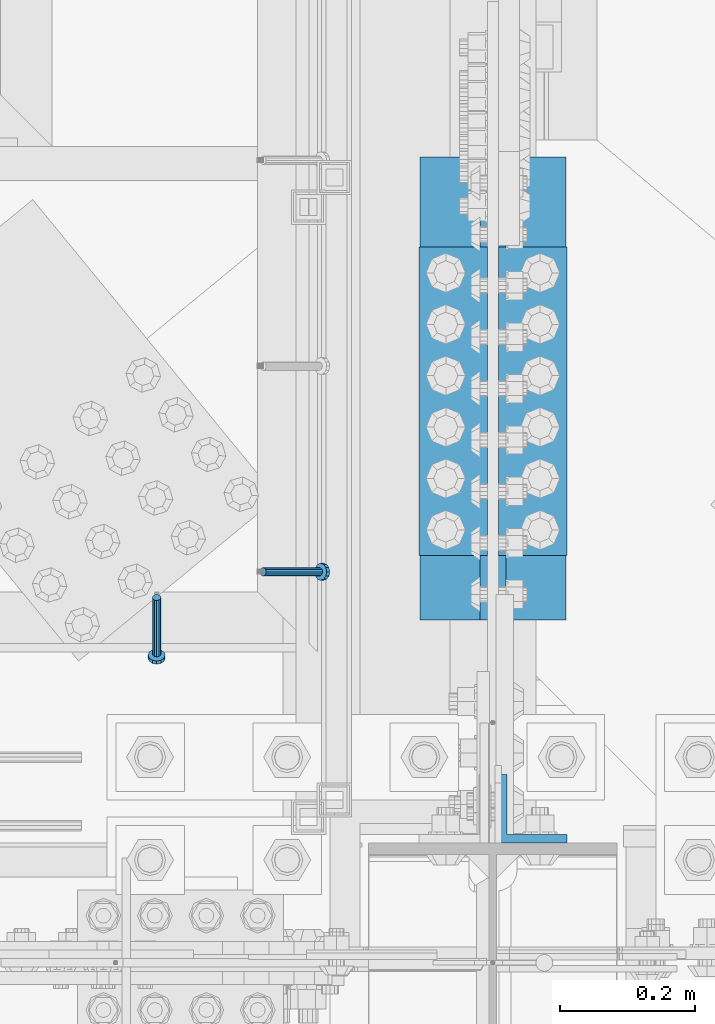
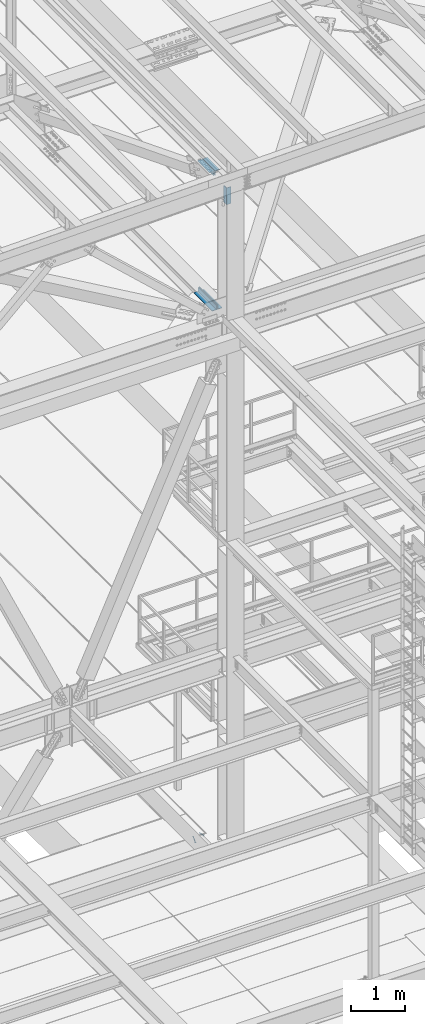
# One storey, part 2109 of 3843: 5 beams, 2 members, 5 elements without a shape of their own.
"""IFC2X3 building model written with IfcOpenShell, lengths in millimetres."""

from ifc_helpers import new_model, si_unit, frame, origin_with_axes, place, context, subcontext, project, spatial, faceted_brep, material, type_object, element, aggregate, save


model = new_model("IFC2X3")

# Units and contexts
model_context = context("Model", 3, precision=1e-05, world=origin_with_axes())
body_context = subcontext(model_context, "Body", "Model", "MODEL_VIEW")
ifc_project = project(units=[si_unit("LENGTHUNIT", "METRE", prefix="MILLI"), si_unit("AREAUNIT", "SQUARE_METRE"), si_unit("VOLUMEUNIT", "CUBIC_METRE"), si_unit("MASSUNIT", "GRAM", prefix="KILO"), si_unit("TIMEUNIT", "SECOND"), si_unit("PLANEANGLEUNIT", "RADIAN"), si_unit("SOLIDANGLEUNIT", "STERADIAN"), si_unit("THERMODYNAMICTEMPERATUREUNIT", "DEGREE_CELSIUS"), si_unit("LUMINOUSINTENSITYUNIT", "LUMEN")], contexts=[model_context])

# Site, building, storey
site_placement = place(None, origin_with_axes())
site = spatial("IfcSite", under=ifc_project, at=site_placement, CompositionType="ELEMENT")
building_placement = place(site_placement, origin_with_axes())
building = spatial("IfcBuilding", under=site, at=building_placement, Name="Undefined", CompositionType="ELEMENT")
storey_placement = place(building_placement, origin_with_axes())
storey = spatial("IfcBuildingStorey", under=building, at=storey_placement, Name="Undefined", CompositionType="ELEMENT", Elevation=0.0)

# Assembly, member
assembly_1_placement = place(storey_placement, origin_with_axes())
assembly_1 = element("IfcElementAssembly", 1, at=assembly_1_placement, inside=storey, Name="EMBED_ANGLE", AssemblyPlace="NOTDEFINED", PredefinedType="RIGID_FRAME")
ifc_material_1 = material(Name="STEEL/A108")
member_type = type_object("IfcMemberType", PredefinedType="NOTDEFINED")
member_1_placement = place(assembly_1_placement, frame((48656.0495, 26195.3375, 30446.6625), z_axis=(0.0, 1.0, 0.0), x_axis=(0.707106781186548, 0.0, -0.707106781186548)))
member_1 = element("IfcMember", 2, at=member_1_placement, type_object=member_type, material=ifc_material_1, Name="HEADED STUD ANCHOR", context=body_context, shape_type="Brep", body=[
    faceted_brep([(7.27595761418343e-12, -3.18000006675175, 5.5), (0.0, -5.49999999998363, 3.1800000667572), (118.110000000976, -5.49999999999091, 3.1800000667572), (118.110000000983, -3.18000006675175, 5.5), (0.0, -6.3499999046162, 0.0), (118.110000000968, -6.34999990461256, 0.0), (0.0, -5.49999999998363, -3.1800000667572), (118.110000000976, -5.49999999999091, -3.1800000667572), (7.27595761418343e-12, -3.18000006675175, -5.5), (118.110000000983, -3.18000006675175, -5.5), (7.27595761418343e-12, -1.81898940354586e-12, -6.34999990463257), (118.110000000968, -1.81898940354586e-12, -6.34999990463257), (0.0, 3.18000006675175, -5.5), (118.110000000968, 3.18000006674811, -5.5), (7.27595761418343e-12, 5.49999999998363, -3.1800000667572), (118.110000000983, 5.49999999998363, -3.1800000667572), (7.27595761418343e-12, 6.3499999046162, 0.0), (118.110000000976, 6.34999990461256, 0.0), (7.27595761418343e-12, 5.49999999998363, 3.1800000667572), (118.110000000983, 5.49999999998363, 3.1800000667572), (0.0, 3.18000006675175, 5.5), (118.110000000968, 3.18000006674811, 5.5), (7.27595761418343e-12, -1.81898940354586e-12, 6.34999990463257), (118.110000000968, -1.81898940354586e-12, 6.34999990463257), (120.650000000991, -10.9899997710909, 6.34999990463257), (120.650000000998, -6.34000015257152, 10.9899997711182), (120.650000000991, -12.6999998092379, 0.0), (120.650000000991, -10.9899997710909, -6.34999990463257), (120.650000000998, -6.34000015257152, -10.9899997711182), (120.650000000991, -1.81898940354586e-12, -12.6899995803833), (120.650000000991, 6.34000015257152, -10.9899997711182), (120.650000000998, 10.9899997710909, -6.34999990463257), (120.650000000991, 12.6999998092342, 0.0), (120.650000000998, 10.9899997710909, 6.34999990463257), (120.650000000991, 6.34000015257152, 10.9899997711182), (120.650000000991, -1.81898940354586e-12, 12.6899995803833), (127.000000001048, -10.9899997710945, 6.34999990463257), (127.000000001048, -6.34000015257152, 10.9899997711182), (127.000000001048, -12.6999998092342, 0.0), (127.000000001048, -10.9899997710945, -6.34999990463257), (127.000000001048, -6.34000015257152, -10.9899997711182), (127.000000001048, 1.81898940354586e-12, -12.6899995803833), (127.000000001048, 6.34000015256788, -10.9899997711182), (127.000000001048, 10.9899997710909, -6.34999990463257), (127.000000001048, 12.6999998092379, 0.0), (127.000000001048, 10.9899997710909, 6.34999990463257), (127.000000001048, 6.34000015256788, 10.9899997711182), (127.000000001048, 1.81898940354586e-12, 12.6899995803833)], [[[0, 1, 2, 3]], [[1, 4, 5, 2]], [[4, 6, 7, 5]], [[6, 8, 9, 7]], [[8, 10, 11, 9]], [[10, 12, 13, 11]], [[12, 14, 15, 13]], [[14, 16, 17, 15]], [[16, 18, 19, 17]], [[18, 20, 21, 19]], [[20, 22, 23, 21]], [[22, 0, 3, 23]], [[22, 20, 18, 16, 14, 12, 10, 8, 6, 4, 1, 0]], [[3, 2, 24, 25]], [[2, 5, 26, 24]], [[5, 7, 27, 26]], [[7, 9, 28, 27]], [[9, 11, 29, 28]], [[11, 13, 30, 29]], [[13, 15, 31, 30]], [[15, 17, 32, 31]], [[17, 19, 33, 32]], [[19, 21, 34, 33]], [[21, 23, 35, 34]], [[23, 3, 25, 35]], [[25, 24, 36, 37]], [[24, 26, 38, 36]], [[26, 27, 39, 38]], [[27, 28, 40, 39]], [[28, 29, 41, 40]], [[29, 30, 42, 41]], [[30, 31, 43, 42]], [[31, 32, 44, 43]], [[32, 33, 45, 44]], [[33, 34, 46, 45]], [[34, 35, 47, 46]], [[35, 25, 37, 47]], [[38, 39, 40, 41, 42, 43, 44, 45, 46, 47, 37, 36]]]),
])
aggregate(assembly_1, [member_1])

assembly_2_placement = place(storey_placement, origin_with_axes())
assembly_2 = element("IfcElementAssembly", 3, at=assembly_2_placement, inside=storey, Name="EMBED_ANGLE", AssemblyPlace="NOTDEFINED", PredefinedType="RIGID_FRAME")
member_2_placement = place(assembly_2_placement, frame((48498.3789921875, 26157.2374995874, 30446.6625), z_axis=(-1.0, 0.0, 0.0), x_axis=(0.0, -0.707106781186548, -0.707106781186548)))
member_2 = element("IfcMember", 4, at=member_2_placement, type_object=member_type, material=ifc_material_1, Name="HEADED STUD ANCHOR", context=body_context, shape_type="Brep", body=[
    faceted_brep([(7.27595761418343e-12, -3.18000006675175, 5.5), (0.0, -5.49999999998363, 3.1800000667572), (118.110000000976, -5.49999999999091, 3.1800000667572), (118.110000000983, -3.18000006675175, 5.5), (0.0, -6.3499999046162, 0.0), (118.110000000968, -6.34999990461256, 0.0), (0.0, -5.49999999998363, -3.1800000667572), (118.110000000976, -5.49999999999091, -3.1800000667572), (7.27595761418343e-12, -3.18000006675175, -5.5), (118.110000000983, -3.18000006675175, -5.5), (7.27595761418343e-12, -1.81898940354586e-12, -6.34999990463257), (118.110000000968, -1.81898940354586e-12, -6.34999990463257), (0.0, 3.18000006675175, -5.5), (118.110000000968, 3.18000006674811, -5.5), (7.27595761418343e-12, 5.49999999998363, -3.1800000667572), (118.110000000983, 5.49999999998363, -3.1800000667572), (7.27595761418343e-12, 6.3499999046162, 0.0), (118.110000000976, 6.34999990461256, 0.0), (7.27595761418343e-12, 5.49999999998363, 3.1800000667572), (118.110000000983, 5.49999999998363, 3.1800000667572), (0.0, 3.18000006675175, 5.5), (118.110000000968, 3.18000006674811, 5.5), (7.27595761418343e-12, -1.81898940354586e-12, 6.34999990463257), (118.110000000968, -1.81898940354586e-12, 6.34999990463257), (120.650000000991, -10.9899997710909, 6.34999990463257), (120.650000000998, -6.34000015257152, 10.9899997711182), (120.650000000991, -12.6999998092379, 0.0), (120.650000000991, -10.9899997710909, -6.34999990463257), (120.650000000998, -6.34000015257152, -10.9899997711182), (120.650000000991, -1.81898940354586e-12, -12.6899995803833), (120.650000000991, 6.34000015257152, -10.9899997711182), (120.650000000998, 10.9899997710909, -6.34999990463257), (120.650000000991, 12.6999998092342, 0.0), (120.650000000998, 10.9899997710909, 6.34999990463257), (120.650000000991, 6.34000015257152, 10.9899997711182), (120.650000000991, -1.81898940354586e-12, 12.6899995803833), (127.000000001048, -10.9899997710945, 6.34999990463257), (127.000000001048, -6.34000015257152, 10.9899997711182), (127.000000001048, -12.6999998092342, 0.0), (127.000000001048, -10.9899997710945, -6.34999990463257), (127.000000001048, -6.34000015257152, -10.9899997711182), (127.000000001048, 1.81898940354586e-12, -12.6899995803833), (127.000000001048, 6.34000015256788, -10.9899997711182), (127.000000001048, 10.9899997710909, -6.34999990463257), (127.000000001048, 12.6999998092379, 0.0), (127.000000001048, 10.9899997710909, 6.34999990463257), (127.000000001048, 6.34000015256788, 10.9899997711182), (127.000000001048, 1.81898940354586e-12, 12.6899995803833)], [[[0, 1, 2, 3]], [[1, 4, 5, 2]], [[4, 6, 7, 5]], [[6, 8, 9, 7]], [[8, 10, 11, 9]], [[10, 12, 13, 11]], [[12, 14, 15, 13]], [[14, 16, 17, 15]], [[16, 18, 19, 17]], [[18, 20, 21, 19]], [[20, 22, 23, 21]], [[22, 0, 3, 23]], [[22, 20, 18, 16, 14, 12, 10, 8, 6, 4, 1, 0]], [[3, 2, 24, 25]], [[2, 5, 26, 24]], [[5, 7, 27, 26]], [[7, 9, 28, 27]], [[9, 11, 29, 28]], [[11, 13, 30, 29]], [[13, 15, 31, 30]], [[15, 17, 32, 31]], [[17, 19, 33, 32]], [[19, 21, 34, 33]], [[21, 23, 35, 34]], [[23, 3, 25, 35]], [[25, 24, 36, 37]], [[24, 26, 38, 36]], [[26, 27, 39, 38]], [[27, 28, 40, 39]], [[28, 29, 41, 40]], [[29, 30, 42, 41]], [[30, 31, 43, 42]], [[31, 32, 44, 43]], [[32, 33, 45, 44]], [[33, 34, 46, 45]], [[34, 35, 47, 46]], [[35, 25, 37, 47]], [[38, 39, 40, 41, 42, 43, 44, 45, 46, 47, 37, 36]]]),
])
aggregate(assembly_2, [member_2])

# Assembly, beam
assembly_3_placement = place(storey_placement, origin_with_axes())
assembly_3 = element("IfcElementAssembly", 5, at=assembly_3_placement, inside=storey, Name="PLATE", AssemblyPlace="NOTDEFINED", PredefinedType="RIGID_FRAME")
ifc_material_2 = material(Name="STEEL/A572-50")
beam_type = type_object("IfcBeamType", Name="L4X4X1/2", PredefinedType="NOTDEFINED")
beam_1_placement = place(assembly_3_placement, frame((49053.7499999995, 26809.7, 42297.35), z_axis=(1.0, 0.0, 0.0), x_axis=(0.0, -1.0, 0.0)))
beam_1 = element("IfcBeam", 6, at=beam_1_placement, type_object=beam_type, material=ifc_material_2, Name="ANGLE", ObjectType="L4X4X1/2", context=body_context, shape_type="Brep", body=[
    faceted_brep([(0.0, 50.8000000000029, -50.8000000000029), (0.0, 50.8000000000029, 50.8000000000029), (685.800000000003, 50.8000000000029, 50.8000000000029), (685.800000000003, 50.8000000000029, -50.8000000000029), (0.0, 38.0999999999985, 50.8000000000029), (685.800000000003, 38.0999999999985, 50.8000000000029), (0.0, 38.0999999999985, -38.0999999999985), (685.800000000003, 38.0999999999985, -38.1000000000058), (0.0, -50.8000000000029, -38.1000000000058), (685.800000000003, -50.8000000000029, -38.1000000000058), (0.0, -50.8000000000029, -50.8000000000029), (685.800000000003, -50.8000000000029, -50.8000000000029)], [[[0, 1, 2, 3]], [[1, 4, 5, 2]], [[4, 6, 7, 5]], [[6, 8, 9, 7]], [[8, 10, 11, 9]], [[10, 0, 3, 11]], [[5, 7, 9, 11, 3, 2]], [[10, 8, 6, 4, 1, 0]]]),
])
aggregate(assembly_3, [beam_1])

assembly_4_placement = place(storey_placement, origin_with_axes())
assembly_4 = element("IfcElementAssembly", 7, at=assembly_4_placement, inside=storey, Name="PLATE", AssemblyPlace="NOTDEFINED", PredefinedType="RIGID_FRAME")
beam_2_placement = place(assembly_4_placement, frame((48939.4501550945, 26123.9000000004, 42297.35), z_axis=(-1.0, 0.0, 0.0), x_axis=(0.0, 1.0, 0.0)))
beam_2 = element("IfcBeam", 8, at=beam_2_placement, type_object=beam_type, material=ifc_material_2, Name="ANGLE", ObjectType="L4X4X1/2", context=body_context, shape_type="Brep", body=[
    faceted_brep([(0.0, 50.8000000000029, -50.8000000000029), (0.0, 50.8000000000029, 50.8000000000029), (685.800000000003, 50.8000000000029, 50.8000000000029), (685.800000000003, 50.8000000000029, -50.8000000000029), (0.0, 38.0999999999985, 50.8000000000029), (685.800000000003, 38.0999999999985, 50.8000000000029), (0.0, 38.0999999999985, -38.0999999999985), (685.800000000003, 38.0999999999985, -38.1000000000058), (0.0, -50.8000000000029, -38.1000000000058), (685.800000000003, -50.8000000000029, -38.1000000000058), (0.0, -50.8000000000029, -50.8000000000029), (685.800000000003, -50.8000000000029, -50.8000000000029)], [[[0, 1, 2, 3]], [[1, 4, 5, 2]], [[4, 6, 7, 5]], [[6, 8, 9, 7]], [[8, 10, 11, 9]], [[10, 0, 3, 11]], [[5, 7, 9, 11, 3, 2]], [[10, 8, 6, 4, 1, 0]]]),
])
aggregate(assembly_4, [beam_2])

# Assembly, beams
assembly_5_placement = place(storey_placement, origin_with_axes())
assembly_5 = element("IfcElementAssembly", 9, at=assembly_5_placement, inside=storey, Name="PLATE", AssemblyPlace="NOTDEFINED", PredefinedType="RIGID_FRAME")
beam_3_placement = place(assembly_5_placement, frame((49055.3375, 26676.35, 45285.4646883345), z_axis=(0.0, 0.0, -1.0), x_axis=(0.0, -1.0, 0.0)))
beam_3 = element("IfcBeam", 10, at=beam_3_placement, type_object=beam_type, material=ifc_material_2, Name="ANGLE", ObjectType="L4X4X1/2", context=body_context, shape_type="Brep", body=[
    faceted_brep([(0.0, 50.8000000000029, -50.8000000000029), (0.0, 50.8000000000029, 50.8000000000029), (457.199999999997, 50.8000000000029, 50.8000000000029), (457.199999999997, 50.8000000000029, -50.8000000000029), (0.0, 38.0999999999985, 50.8000000000029), (457.199999999997, 38.0999999999985, 50.8000000000029), (0.0, 38.0999999999985, -38.0999999999985), (457.199999999997, 38.0999999999985, -38.0999999999985), (0.0, -50.8000000000029, -38.1000000000058), (457.199999999997, -50.8000000000029, -38.0999999999985), (0.0, -50.8000000000029, -50.8000000000029), (457.199999999997, -50.8000000000029, -50.8000000000029)], [[[0, 1, 2, 3]], [[1, 4, 5, 2]], [[4, 6, 7, 5]], [[6, 8, 9, 7]], [[8, 10, 11, 9]], [[10, 0, 3, 11]], [[5, 7, 9, 11, 3, 2]], [[10, 8, 6, 4, 1, 0]]]),
])
beam_4_placement = place(assembly_5_placement, frame((48937.8625, 26219.15, 45285.4646883345), z_axis=(0.0, 0.0, -1.0), x_axis=(0.0, 1.0, 0.0)))
beam_4 = element("IfcBeam", 11, at=beam_4_placement, type_object=beam_type, material=ifc_material_2, Name="ANGLE", ObjectType="L4X4X1/2", context=body_context, shape_type="Brep", body=[
    faceted_brep([(0.0, 50.8000000000029, -50.8000000000029), (0.0, 50.8000000000029, 50.8000000000029), (457.199999999997, 50.8000000000029, 50.8000000000029), (457.199999999997, 50.8000000000029, -50.8000000000029), (0.0, 38.0999999999985, 50.8000000000029), (457.199999999997, 38.0999999999985, 50.8000000000029), (0.0, 38.0999999999985, -38.0999999999985), (457.199999999997, 38.0999999999985, -38.0999999999985), (0.0, -50.8000000000029, -38.1000000000058), (457.199999999997, -50.8000000000029, -38.0999999999985), (0.0, -50.8000000000029, -50.8000000000029), (457.199999999997, -50.8000000000029, -50.8000000000029)], [[[0, 1, 2, 3]], [[1, 4, 5, 2]], [[4, 6, 7, 5]], [[6, 8, 9, 7]], [[8, 10, 11, 9]], [[10, 0, 3, 11]], [[5, 7, 9, 11, 3, 2]], [[10, 8, 6, 4, 1, 0]]]),
])
beam_5_placement = place(assembly_5_placement, frame((49055.3375, 25844.4999999841, 45202.9146883348), z_axis=(0.0, 1.0, 0.0), x_axis=(0.0, 0.0, -1.0)))
beam_5 = element("IfcBeam", 12, at=beam_5_placement, type_object=beam_type, material=ifc_material_2, Name="ANGLE", ObjectType="L4X4X1/2", context=body_context, shape_type="Brep", body=[
    faceted_brep([(0.0, 50.8000000000029, -50.8000000000029), (0.0, 50.8000000000029, 50.8000000000029), (381.0, 50.8000000000029, 50.8000000000029), (381.0, 50.8000000000029, -50.8000000000029), (0.0, 38.0999999999985, 50.8000000000029), (381.0, 38.0999999999985, 50.8000000000029), (0.0, 38.0999999999985, -38.0999999999985), (381.0, 38.0999999999985, -38.1000000000058), (0.0, -50.8000000000029, -38.1000000000058), (381.0, -50.8000000000029, -38.1000000000058), (0.0, -50.8000000000029, -50.8000000000029), (381.0, -50.8000000000029, -50.8000000000029)], [[[0, 1, 2, 3]], [[1, 4, 5, 2]], [[4, 6, 7, 5]], [[6, 8, 9, 7]], [[8, 10, 11, 9]], [[10, 0, 3, 11]], [[5, 7, 9, 11, 3, 2]], [[10, 8, 6, 4, 1, 0]]]),
])
aggregate(assembly_5, [beam_3, beam_4, beam_5])

save(model, "model.ifc")
